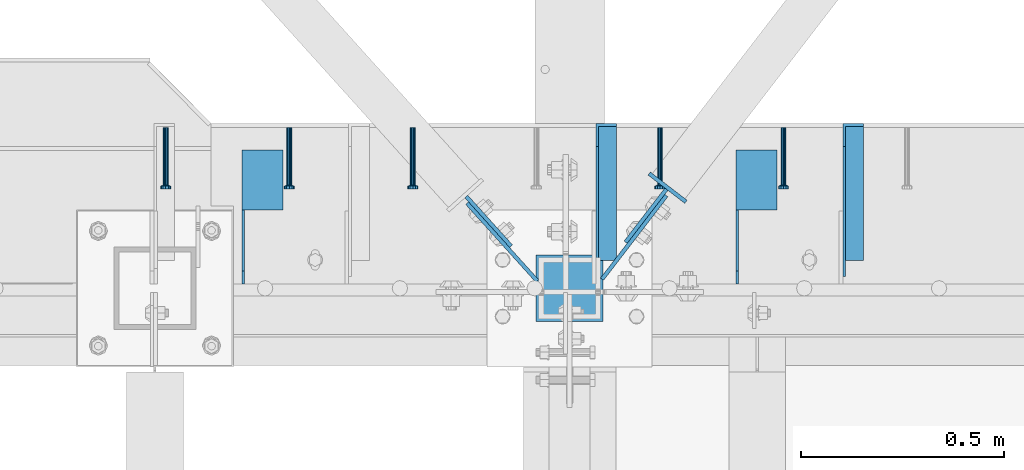
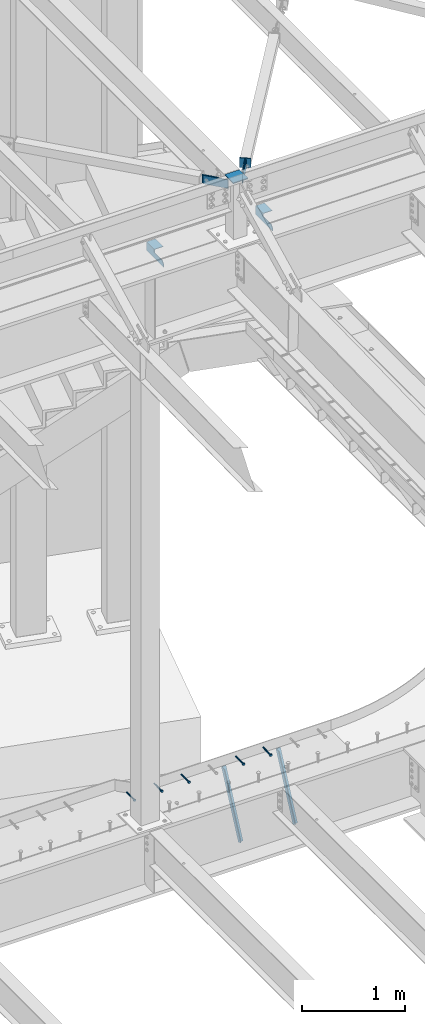
# One storey, part 1375 of 1763: 13 beams, 2 members, 10 elements without a shape of their own.
"""IFC2X3 building model written with IfcOpenShell, lengths in millimetres."""

from ifc_helpers import new_model, si_unit, frame, origin_with_axes, place, context, subcontext, project, spatial, faceted_brep, material, type_object, element, aggregate, save


model = new_model("IFC2X3")

# Units and contexts
model_context = context("Model", 3, precision=1e-05, world=origin_with_axes())
body_context = subcontext(model_context, "Body", "Model", "MODEL_VIEW")
ifc_project = project(units=[si_unit("LENGTHUNIT", "METRE", prefix="MILLI"), si_unit("AREAUNIT", "SQUARE_METRE"), si_unit("VOLUMEUNIT", "CUBIC_METRE"), si_unit("MASSUNIT", "GRAM", prefix="KILO"), si_unit("TIMEUNIT", "SECOND"), si_unit("PLANEANGLEUNIT", "RADIAN"), si_unit("SOLIDANGLEUNIT", "STERADIAN"), si_unit("THERMODYNAMICTEMPERATUREUNIT", "DEGREE_CELSIUS"), si_unit("LUMINOUSINTENSITYUNIT", "LUMEN")], contexts=[model_context])

# Site, building, storey
site_placement = place(None, origin_with_axes())
site = spatial("IfcSite", under=ifc_project, at=site_placement, CompositionType="ELEMENT")
building_placement = place(site_placement, origin_with_axes())
building = spatial("IfcBuilding", under=site, at=building_placement, Name="Undefined", CompositionType="ELEMENT")
storey_placement = place(building_placement, origin_with_axes())
storey = spatial("IfcBuildingStorey", under=building, at=storey_placement, Name="Undefined", CompositionType="ELEMENT", Elevation=0.0)

# Assembly, beam
assembly_1_placement = place(storey_placement, origin_with_axes())
assembly_1 = element("IfcElementAssembly", 1, at=assembly_1_placement, inside=storey, Name="HEADED STUD ANCHOR", AssemblyPlace="NOTDEFINED", PredefinedType="RIGID_FRAME")
ifc_material_1 = material(Name="STEEL/A108")
beam_type_1 = type_object("IfcBeamType", PredefinedType="NOTDEFINED")
beam_1_placement = place(assembly_1_placement, frame((-25449.0466486983, 52517.7065918569, 5264.23140606069), z_axis=(0.0, 0.0, 1.0), x_axis=(0.0, -1.0, 0.0)))
beam_1 = element("IfcBeam", 2, at=beam_1_placement, type_object=beam_type_1, material=ifc_material_1, Name="HEADED STUD ANCHOR", context=body_context, shape_type="Brep", body=[
    faceted_brep([(0.0, -3.1800000667572, 5.5), (0.0, -5.5, 3.1800000667572), (141.732000000002, -5.5, 3.1800000667572), (141.732000000002, -3.1800000667572, 5.5), (0.0, -6.34999999999491, 1.45519152283669e-11), (141.732000000002, -6.34999990463257, 0.0), (0.0, -5.5, -3.1800000667572), (141.732000000002, -5.5, -3.1800000667572), (0.0, -3.1800000667572, -5.5), (141.732000000002, -3.1800000667572, -5.5), (0.0, 0.0, -6.34999990463257), (141.732000000002, 0.0, -6.34999990463257), (0.0, 3.1800000667572, -5.5), (141.732000000002, 3.1800000667572, -5.5), (0.0, 5.5, -3.1800000667572), (141.732000000002, 5.5, -3.1800000667572), (0.0, 6.34999999999491, -2.91038304567337e-11), (141.732000000002, 6.34999990463257, 0.0), (0.0, 5.5, 3.1800000667572), (141.732000000002, 5.5, 3.1800000667572), (0.0, 3.1800000667572, 5.5), (141.732000000002, 3.1800000667572, 5.5), (0.0, 0.0, 6.34999990463257), (141.732000000002, 0.0, 6.34999990463257), (144.780000000001, -10.9899997711182, 6.34999990463257), (144.780000000001, -6.34000015258789, 10.9899997711182), (144.780000000001, -12.6999998092651, 0.0), (144.780000000001, -10.9899997711182, -6.34999990463257), (144.780000000001, -6.34000015258789, -10.9899997711182), (144.780000000001, 0.0, -12.6899995803833), (144.780000000001, 6.34000015258789, -10.9899997711182), (144.780000000001, 10.9899997711182, -6.34999990463257), (144.780000000001, 12.6999998092651, 0.0), (144.780000000001, 10.9899997711182, 6.34999990463257), (144.780000000001, 6.34000015258789, 10.9899997711182), (144.780000000001, 0.0, 12.6899995803833), (152.400000000001, -10.9899997711182, 6.34999990463257), (152.400000000001, -6.34000015258789, 10.9899997711182), (152.400000000001, -12.6999998092651, 0.0), (152.400000000001, -10.9899997711182, -6.34999990463257), (152.400000000001, -6.34000015258789, -10.9899997711182), (152.400000000001, 0.0, -12.6899995803833), (152.400000000001, 6.34000015258789, -10.9899997711182), (152.400000000001, 10.9899997711182, -6.34999990463257), (152.400000000001, 12.6999998092651, 0.0), (152.400000000001, 10.9899997711182, 6.34999990463257), (152.400000000001, 6.34000015258789, 10.9899997711182), (152.400000000001, 0.0, 12.6899995803833)], [[[0, 1, 2, 3]], [[1, 4, 5, 2]], [[4, 6, 7, 5]], [[6, 8, 9, 7]], [[8, 10, 11, 9]], [[10, 12, 13, 11]], [[12, 14, 15, 13]], [[14, 16, 17, 15]], [[16, 18, 19, 17]], [[18, 20, 21, 19]], [[20, 22, 23, 21]], [[22, 0, 3, 23]], [[22, 20, 18, 16, 14, 12, 10, 8, 6, 4, 1, 0]], [[3, 2, 24, 25]], [[2, 5, 26, 24]], [[5, 7, 27, 26]], [[7, 9, 28, 27]], [[9, 11, 29, 28]], [[11, 13, 30, 29]], [[13, 15, 31, 30]], [[15, 17, 32, 31]], [[17, 19, 33, 32]], [[19, 21, 34, 33]], [[21, 23, 35, 34]], [[23, 3, 25, 35]], [[25, 24, 36, 37]], [[24, 26, 38, 36]], [[26, 27, 39, 38]], [[27, 28, 40, 39]], [[28, 29, 41, 40]], [[29, 30, 42, 41]], [[30, 31, 43, 42]], [[31, 32, 44, 43]], [[32, 33, 45, 44]], [[33, 34, 46, 45]], [[34, 35, 47, 46]], [[35, 25, 37, 47]], [[38, 39, 40, 41, 42, 43, 44, 45, 46, 47, 37, 36]]]),
])
aggregate(assembly_1, [beam_1])

assembly_2_placement = place(storey_placement, origin_with_axes())
assembly_2 = element("IfcElementAssembly", 3, at=assembly_2_placement, inside=storey, Name="HEADED STUD ANCHOR", AssemblyPlace="NOTDEFINED", PredefinedType="RIGID_FRAME")
beam_2_placement = place(assembly_2_placement, frame((-25753.8466486983, 52517.7065918569, 5264.23140606069), z_axis=(0.0, 0.0, 1.0), x_axis=(0.0, -1.0, 0.0)))
beam_2 = element("IfcBeam", 4, at=beam_2_placement, type_object=beam_type_1, material=ifc_material_1, Name="HEADED STUD ANCHOR", context=body_context, shape_type="Brep", body=[
    faceted_brep([(0.0, -3.1800000667572, 5.5), (0.0, -5.5, 3.1800000667572), (141.732000000002, -5.5, 3.1800000667572), (141.732000000002, -3.1800000667572, 5.5), (0.0, -6.34999999999491, 1.45519152283669e-11), (141.732000000002, -6.34999990463257, 0.0), (0.0, -5.5, -3.1800000667572), (141.732000000002, -5.5, -3.1800000667572), (0.0, -3.1800000667572, -5.5), (141.732000000002, -3.1800000667572, -5.5), (0.0, 0.0, -6.34999990463257), (141.732000000002, 0.0, -6.34999990463257), (0.0, 3.1800000667572, -5.5), (141.732000000002, 3.1800000667572, -5.5), (0.0, 5.5, -3.1800000667572), (141.732000000002, 5.5, -3.1800000667572), (0.0, 6.34999999999491, -2.91038304567337e-11), (141.732000000002, 6.34999990463257, 0.0), (0.0, 5.5, 3.1800000667572), (141.732000000002, 5.5, 3.1800000667572), (0.0, 3.1800000667572, 5.5), (141.732000000002, 3.1800000667572, 5.5), (0.0, 0.0, 6.34999990463257), (141.732000000002, 0.0, 6.34999990463257), (144.780000000001, -10.9899997711182, 6.34999990463257), (144.780000000001, -6.34000015258789, 10.9899997711182), (144.780000000001, -12.6999998092651, 0.0), (144.780000000001, -10.9899997711182, -6.34999990463257), (144.780000000001, -6.34000015258789, -10.9899997711182), (144.780000000001, 0.0, -12.6899995803833), (144.780000000001, 6.34000015258789, -10.9899997711182), (144.780000000001, 10.9899997711182, -6.34999990463257), (144.780000000001, 12.6999998092651, 0.0), (144.780000000001, 10.9899997711182, 6.34999990463257), (144.780000000001, 6.34000015258789, 10.9899997711182), (144.780000000001, 0.0, 12.6899995803833), (152.400000000001, -10.9899997711182, 6.34999990463257), (152.400000000001, -6.34000015258789, 10.9899997711182), (152.400000000001, -12.6999998092651, 0.0), (152.400000000001, -10.9899997711182, -6.34999990463257), (152.400000000001, -6.34000015258789, -10.9899997711182), (152.400000000001, 0.0, -12.6899995803833), (152.400000000001, 6.34000015258789, -10.9899997711182), (152.400000000001, 10.9899997711182, -6.34999990463257), (152.400000000001, 12.6999998092651, 0.0), (152.400000000001, 10.9899997711182, 6.34999990463257), (152.400000000001, 6.34000015258789, 10.9899997711182), (152.400000000001, 0.0, 12.6899995803833)], [[[0, 1, 2, 3]], [[1, 4, 5, 2]], [[4, 6, 7, 5]], [[6, 8, 9, 7]], [[8, 10, 11, 9]], [[10, 12, 13, 11]], [[12, 14, 15, 13]], [[14, 16, 17, 15]], [[16, 18, 19, 17]], [[18, 20, 21, 19]], [[20, 22, 23, 21]], [[22, 0, 3, 23]], [[22, 20, 18, 16, 14, 12, 10, 8, 6, 4, 1, 0]], [[3, 2, 24, 25]], [[2, 5, 26, 24]], [[5, 7, 27, 26]], [[7, 9, 28, 27]], [[9, 11, 29, 28]], [[11, 13, 30, 29]], [[13, 15, 31, 30]], [[15, 17, 32, 31]], [[17, 19, 33, 32]], [[19, 21, 34, 33]], [[21, 23, 35, 34]], [[23, 3, 25, 35]], [[25, 24, 36, 37]], [[24, 26, 38, 36]], [[26, 27, 39, 38]], [[27, 28, 40, 39]], [[28, 29, 41, 40]], [[29, 30, 42, 41]], [[30, 31, 43, 42]], [[31, 32, 44, 43]], [[32, 33, 45, 44]], [[33, 34, 46, 45]], [[34, 35, 47, 46]], [[35, 25, 37, 47]], [[38, 39, 40, 41, 42, 43, 44, 45, 46, 47, 37, 36]]]),
])
aggregate(assembly_2, [beam_2])

assembly_3_placement = place(storey_placement, origin_with_axes())
assembly_3 = element("IfcElementAssembly", 5, at=assembly_3_placement, inside=storey, Name="HEADED STUD ANCHOR", AssemblyPlace="NOTDEFINED", PredefinedType="RIGID_FRAME")
beam_3_placement = place(assembly_3_placement, frame((-26363.4466486983, 52517.7065918569, 5264.23140606069), z_axis=(0.0, 0.0, 1.0), x_axis=(0.0, -1.0, 0.0)))
beam_3 = element("IfcBeam", 6, at=beam_3_placement, type_object=beam_type_1, material=ifc_material_1, Name="HEADED STUD ANCHOR", context=body_context, shape_type="Brep", body=[
    faceted_brep([(0.0, -3.1800000667572, 5.5), (0.0, -5.5, 3.1800000667572), (141.732000000002, -5.5, 3.1800000667572), (141.732000000002, -3.1800000667572, 5.5), (0.0, -6.34999999999491, 1.45519152283669e-11), (141.732000000002, -6.34999990463257, 0.0), (0.0, -5.5, -3.1800000667572), (141.732000000002, -5.5, -3.1800000667572), (0.0, -3.1800000667572, -5.5), (141.732000000002, -3.1800000667572, -5.5), (0.0, 0.0, -6.34999990463257), (141.732000000002, 0.0, -6.34999990463257), (0.0, 3.1800000667572, -5.5), (141.732000000002, 3.1800000667572, -5.5), (0.0, 5.5, -3.1800000667572), (141.732000000002, 5.5, -3.1800000667572), (0.0, 6.34999999999491, -2.91038304567337e-11), (141.732000000002, 6.34999990463257, 0.0), (0.0, 5.5, 3.1800000667572), (141.732000000002, 5.5, 3.1800000667572), (0.0, 3.1800000667572, 5.5), (141.732000000002, 3.1800000667572, 5.5), (0.0, 0.0, 6.34999990463257), (141.732000000002, 0.0, 6.34999990463257), (144.780000000001, -10.9899997711182, 6.34999990463257), (144.780000000001, -6.34000015258789, 10.9899997711182), (144.780000000001, -12.6999998092651, 0.0), (144.780000000001, -10.9899997711182, -6.34999990463257), (144.780000000001, -6.34000015258789, -10.9899997711182), (144.780000000001, 0.0, -12.6899995803833), (144.780000000001, 6.34000015258789, -10.9899997711182), (144.780000000001, 10.9899997711182, -6.34999990463257), (144.780000000001, 12.6999998092651, 0.0), (144.780000000001, 10.9899997711182, 6.34999990463257), (144.780000000001, 6.34000015258789, 10.9899997711182), (144.780000000001, 0.0, 12.6899995803833), (152.400000000001, -10.9899997711182, 6.34999990463257), (152.400000000001, -6.34000015258789, 10.9899997711182), (152.400000000001, -12.6999998092651, 0.0), (152.400000000001, -10.9899997711182, -6.34999990463257), (152.400000000001, -6.34000015258789, -10.9899997711182), (152.400000000001, 0.0, -12.6899995803833), (152.400000000001, 6.34000015258789, -10.9899997711182), (152.400000000001, 10.9899997711182, -6.34999990463257), (152.400000000001, 12.6999998092651, 0.0), (152.400000000001, 10.9899997711182, 6.34999990463257), (152.400000000001, 6.34000015258789, 10.9899997711182), (152.400000000001, 0.0, 12.6899995803833)], [[[0, 1, 2, 3]], [[1, 4, 5, 2]], [[4, 6, 7, 5]], [[6, 8, 9, 7]], [[8, 10, 11, 9]], [[10, 12, 13, 11]], [[12, 14, 15, 13]], [[14, 16, 17, 15]], [[16, 18, 19, 17]], [[18, 20, 21, 19]], [[20, 22, 23, 21]], [[22, 0, 3, 23]], [[22, 20, 18, 16, 14, 12, 10, 8, 6, 4, 1, 0]], [[3, 2, 24, 25]], [[2, 5, 26, 24]], [[5, 7, 27, 26]], [[7, 9, 28, 27]], [[9, 11, 29, 28]], [[11, 13, 30, 29]], [[13, 15, 31, 30]], [[15, 17, 32, 31]], [[17, 19, 33, 32]], [[19, 21, 34, 33]], [[21, 23, 35, 34]], [[23, 3, 25, 35]], [[25, 24, 36, 37]], [[24, 26, 38, 36]], [[26, 27, 39, 38]], [[27, 28, 40, 39]], [[28, 29, 41, 40]], [[29, 30, 42, 41]], [[30, 31, 43, 42]], [[31, 32, 44, 43]], [[32, 33, 45, 44]], [[33, 34, 46, 45]], [[34, 35, 47, 46]], [[35, 25, 37, 47]], [[38, 39, 40, 41, 42, 43, 44, 45, 46, 47, 37, 36]]]),
])
aggregate(assembly_3, [beam_3])

assembly_4_placement = place(storey_placement, origin_with_axes())
assembly_4 = element("IfcElementAssembly", 7, at=assembly_4_placement, inside=storey, Name="HEADED STUD ANCHOR", AssemblyPlace="NOTDEFINED", PredefinedType="RIGID_FRAME")
beam_4_placement = place(assembly_4_placement, frame((-26668.2466486983, 52517.7065918569, 5264.23140606069), z_axis=(0.0, 0.0, 1.0), x_axis=(0.0, -1.0, 0.0)))
beam_4 = element("IfcBeam", 8, at=beam_4_placement, type_object=beam_type_1, material=ifc_material_1, Name="HEADED STUD ANCHOR", context=body_context, shape_type="Brep", body=[
    faceted_brep([(0.0, -3.1800000667572, 5.5), (0.0, -5.5, 3.1800000667572), (141.732000000002, -5.5, 3.1800000667572), (141.732000000002, -3.1800000667572, 5.5), (0.0, -6.34999999999491, 1.45519152283669e-11), (141.732000000002, -6.34999990463257, 0.0), (0.0, -5.5, -3.1800000667572), (141.732000000002, -5.5, -3.1800000667572), (0.0, -3.1800000667572, -5.5), (141.732000000002, -3.1800000667572, -5.5), (0.0, 0.0, -6.34999990463257), (141.732000000002, 0.0, -6.34999990463257), (0.0, 3.1800000667572, -5.5), (141.732000000002, 3.1800000667572, -5.5), (0.0, 5.5, -3.1800000667572), (141.732000000002, 5.5, -3.1800000667572), (0.0, 6.34999999999491, -2.91038304567337e-11), (141.732000000002, 6.34999990463257, 0.0), (0.0, 5.5, 3.1800000667572), (141.732000000002, 5.5, 3.1800000667572), (0.0, 3.1800000667572, 5.5), (141.732000000002, 3.1800000667572, 5.5), (0.0, 0.0, 6.34999990463257), (141.732000000002, 0.0, 6.34999990463257), (144.780000000001, -10.9899997711182, 6.34999990463257), (144.780000000001, -6.34000015258789, 10.9899997711182), (144.780000000001, -12.6999998092651, 0.0), (144.780000000001, -10.9899997711182, -6.34999990463257), (144.780000000001, -6.34000015258789, -10.9899997711182), (144.780000000001, 0.0, -12.6899995803833), (144.780000000001, 6.34000015258789, -10.9899997711182), (144.780000000001, 10.9899997711182, -6.34999990463257), (144.780000000001, 12.6999998092651, 0.0), (144.780000000001, 10.9899997711182, 6.34999990463257), (144.780000000001, 6.34000015258789, 10.9899997711182), (144.780000000001, 0.0, 12.6899995803833), (152.400000000001, -10.9899997711182, 6.34999990463257), (152.400000000001, -6.34000015258789, 10.9899997711182), (152.400000000001, -12.6999998092651, 0.0), (152.400000000001, -10.9899997711182, -6.34999990463257), (152.400000000001, -6.34000015258789, -10.9899997711182), (152.400000000001, 0.0, -12.6899995803833), (152.400000000001, 6.34000015258789, -10.9899997711182), (152.400000000001, 10.9899997711182, -6.34999990463257), (152.400000000001, 12.6999998092651, 0.0), (152.400000000001, 10.9899997711182, 6.34999990463257), (152.400000000001, 6.34000015258789, 10.9899997711182), (152.400000000001, 0.0, 12.6899995803833)], [[[0, 1, 2, 3]], [[1, 4, 5, 2]], [[4, 6, 7, 5]], [[6, 8, 9, 7]], [[8, 10, 11, 9]], [[10, 12, 13, 11]], [[12, 14, 15, 13]], [[14, 16, 17, 15]], [[16, 18, 19, 17]], [[18, 20, 21, 19]], [[20, 22, 23, 21]], [[22, 0, 3, 23]], [[22, 20, 18, 16, 14, 12, 10, 8, 6, 4, 1, 0]], [[3, 2, 24, 25]], [[2, 5, 26, 24]], [[5, 7, 27, 26]], [[7, 9, 28, 27]], [[9, 11, 29, 28]], [[11, 13, 30, 29]], [[13, 15, 31, 30]], [[15, 17, 32, 31]], [[17, 19, 33, 32]], [[19, 21, 34, 33]], [[21, 23, 35, 34]], [[23, 3, 25, 35]], [[25, 24, 36, 37]], [[24, 26, 38, 36]], [[26, 27, 39, 38]], [[27, 28, 40, 39]], [[28, 29, 41, 40]], [[29, 30, 42, 41]], [[30, 31, 43, 42]], [[31, 32, 44, 43]], [[32, 33, 45, 44]], [[33, 34, 46, 45]], [[34, 35, 47, 46]], [[35, 25, 37, 47]], [[38, 39, 40, 41, 42, 43, 44, 45, 46, 47, 37, 36]]]),
])
aggregate(assembly_4, [beam_4])

assembly_5_placement = place(storey_placement, origin_with_axes())
assembly_5 = element("IfcElementAssembly", 9, at=assembly_5_placement, inside=storey, Name="HEADED STUD ANCHOR", AssemblyPlace="NOTDEFINED", PredefinedType="RIGID_FRAME")
beam_5_placement = place(assembly_5_placement, frame((-26973.0466486983, 52517.7065918569, 5264.23140606069), z_axis=(0.0, 0.0, 1.0), x_axis=(0.0, -1.0, 0.0)))
beam_5 = element("IfcBeam", 10, at=beam_5_placement, type_object=beam_type_1, material=ifc_material_1, Name="HEADED STUD ANCHOR", context=body_context, shape_type="Brep", body=[
    faceted_brep([(0.0, -3.1800000667572, 5.5), (0.0, -5.5, 3.1800000667572), (141.732000000002, -5.5, 3.1800000667572), (141.732000000002, -3.1800000667572, 5.5), (0.0, -6.34999999999491, 1.45519152283669e-11), (141.732000000002, -6.34999990463257, 0.0), (0.0, -5.5, -3.1800000667572), (141.732000000002, -5.5, -3.1800000667572), (0.0, -3.1800000667572, -5.5), (141.732000000002, -3.1800000667572, -5.5), (0.0, 0.0, -6.34999990463257), (141.732000000002, 0.0, -6.34999990463257), (0.0, 3.1800000667572, -5.5), (141.732000000002, 3.1800000667572, -5.5), (0.0, 5.5, -3.1800000667572), (141.732000000002, 5.5, -3.1800000667572), (0.0, 6.34999999999491, -2.91038304567337e-11), (141.732000000002, 6.34999990463257, 0.0), (0.0, 5.5, 3.1800000667572), (141.732000000002, 5.5, 3.1800000667572), (0.0, 3.1800000667572, 5.5), (141.732000000002, 3.1800000667572, 5.5), (0.0, 0.0, 6.34999990463257), (141.732000000002, 0.0, 6.34999990463257), (144.780000000001, -10.9899997711182, 6.34999990463257), (144.780000000001, -6.34000015258789, 10.9899997711182), (144.780000000001, -12.6999998092651, 0.0), (144.780000000001, -10.9899997711182, -6.34999990463257), (144.780000000001, -6.34000015258789, -10.9899997711182), (144.780000000001, 0.0, -12.6899995803833), (144.780000000001, 6.34000015258789, -10.9899997711182), (144.780000000001, 10.9899997711182, -6.34999990463257), (144.780000000001, 12.6999998092651, 0.0), (144.780000000001, 10.9899997711182, 6.34999990463257), (144.780000000001, 6.34000015258789, 10.9899997711182), (144.780000000001, 0.0, 12.6899995803833), (152.400000000001, -10.9899997711182, 6.34999990463257), (152.400000000001, -6.34000015258789, 10.9899997711182), (152.400000000001, -12.6999998092651, 0.0), (152.400000000001, -10.9899997711182, -6.34999990463257), (152.400000000001, -6.34000015258789, -10.9899997711182), (152.400000000001, 0.0, -12.6899995803833), (152.400000000001, 6.34000015258789, -10.9899997711182), (152.400000000001, 10.9899997711182, -6.34999990463257), (152.400000000001, 12.6999998092651, 0.0), (152.400000000001, 10.9899997711182, 6.34999990463257), (152.400000000001, 6.34000015258789, 10.9899997711182), (152.400000000001, 0.0, 12.6899995803833)], [[[0, 1, 2, 3]], [[1, 4, 5, 2]], [[4, 6, 7, 5]], [[6, 8, 9, 7]], [[8, 10, 11, 9]], [[10, 12, 13, 11]], [[12, 14, 15, 13]], [[14, 16, 17, 15]], [[16, 18, 19, 17]], [[18, 20, 21, 19]], [[20, 22, 23, 21]], [[22, 0, 3, 23]], [[22, 20, 18, 16, 14, 12, 10, 8, 6, 4, 1, 0]], [[3, 2, 24, 25]], [[2, 5, 26, 24]], [[5, 7, 27, 26]], [[7, 9, 28, 27]], [[9, 11, 29, 28]], [[11, 13, 30, 29]], [[13, 15, 31, 30]], [[15, 17, 32, 31]], [[17, 19, 33, 32]], [[19, 21, 34, 33]], [[21, 23, 35, 34]], [[23, 3, 25, 35]], [[25, 24, 36, 37]], [[24, 26, 38, 36]], [[26, 27, 39, 38]], [[27, 28, 40, 39]], [[28, 29, 41, 40]], [[29, 30, 42, 41]], [[30, 31, 43, 42]], [[31, 32, 44, 43]], [[32, 33, 45, 44]], [[33, 34, 46, 45]], [[34, 35, 47, 46]], [[35, 25, 37, 47]], [[38, 39, 40, 41, 42, 43, 44, 45, 46, 47, 37, 36]]]),
])
aggregate(assembly_5, [beam_5])

# Assembly, members
assembly_6_placement = place(storey_placement, origin_with_axes())
assembly_6 = element("IfcElementAssembly", 11, at=assembly_6_placement, inside=storey, Name="BEAM", AssemblyPlace="NOTDEFINED", PredefinedType="RIGID_FRAME")
ifc_material_2 = material(Name="STEEL/A36")
member_type = type_object("IfcMemberType", Name="L2X2X1/4", PredefinedType="NOTDEFINED")
member_1_placement = place(assembly_6_placement, frame((-25277.0370109278, 52172.6912662575, 4509.47070362112), z_axis=(0.0, -0.902782435029662, 0.430097518014128), x_axis=(0.0, 0.43009751801413, 0.902782435029662)))
member_1 = element("IfcMember", 12, at=member_1_placement, type_object=member_type, material=ifc_material_2, Name="ANGLE", ObjectType="L2X2X1/4", context=body_context, shape_type="Brep", body=[
    faceted_brep([(-1.45519152283669e-11, 25.4000000000015, -25.3999999999869), (1.45519152283669e-11, 25.4000000000015, 25.3999999999796), (746.475333672606, 25.4000000000015, 25.3999999987791), (770.677127003386, 25.4000000000015, -25.400000001122), (1.45519152283669e-11, 19.0499999999993, 25.3999999999796), (746.475333672606, 19.0499999999993, 25.3999999987791), (-7.27595761418343e-12, 19.0499999999993, -19.0499999999956), (767.651902837039, 19.0499999999993, -19.050000001138), (-7.27595761418343e-12, -25.4000000000015, -19.0499999999956), (767.651902837039, -25.4000000000015, -19.050000001138), (-1.45519152283669e-11, -25.4000000000015, -25.3999999999869), (770.677127003386, -25.4000000000015, -25.400000001122)], [[[0, 1, 2, 3]], [[1, 4, 5, 2]], [[4, 6, 7, 5]], [[6, 8, 9, 7]], [[8, 10, 11, 9]], [[10, 0, 3, 11]], [[5, 7, 9, 11, 3, 2]], [[10, 8, 6, 4, 1, 0]]]),
])
member_2_placement = place(assembly_6_placement, frame((-25886.6370109278, 52172.6912662575, 4509.47070362112), z_axis=(0.0, -0.902782435029662, 0.430097518014128), x_axis=(0.0, 0.43009751801413, 0.902782435029662)))
member_2 = element("IfcMember", 13, at=member_2_placement, type_object=member_type, material=ifc_material_2, Name="ANGLE", ObjectType="L2X2X1/4", context=body_context, shape_type="Brep", body=[
    faceted_brep([(-1.45519152283669e-11, 25.4000000000015, -25.3999999999869), (1.45519152283669e-11, 25.4000000000015, 25.3999999999796), (746.475333672606, 25.4000000000015, 25.3999999987791), (770.677127003386, 25.4000000000015, -25.400000001122), (1.45519152283669e-11, 19.0499999999993, 25.3999999999796), (746.475333672606, 19.0499999999993, 25.3999999987791), (-7.27595761418343e-12, 19.0499999999993, -19.0499999999956), (767.651902837039, 19.0499999999993, -19.050000001138), (-7.27595761418343e-12, -25.4000000000015, -19.0499999999956), (767.651902837039, -25.4000000000015, -19.050000001138), (-1.45519152283669e-11, -25.4000000000015, -25.3999999999869), (770.677127003386, -25.4000000000015, -25.400000001122)], [[[0, 1, 2, 3]], [[1, 4, 5, 2]], [[4, 6, 7, 5]], [[6, 8, 9, 7]], [[8, 10, 11, 9]], [[10, 0, 3, 11]], [[5, 7, 9, 11, 3, 2]], [[10, 8, 6, 4, 1, 0]]]),
])
aggregate(assembly_6, [member_1, member_2])

# Assembly, beams
assembly_7_placement = place(storey_placement, origin_with_axes())
assembly_7 = element("IfcElementAssembly", 14, at=assembly_7_placement, inside=storey, Name="BEAM", AssemblyPlace="NOTDEFINED", PredefinedType="RIGID_FRAME")
beam_type_2 = type_object("IfcBeamType", Name="L4X4X1/4", PredefinedType="NOTDEFINED")
beam_6_placement = place(assembly_7_placement, frame((-25515.3247736984, 52462.1124819023, 11696.6999917654), z_axis=(0.0, 0.0, -1.0), x_axis=(0.0, -1.0, 0.0)))
beam_6 = element("IfcBeam", 15, at=beam_6_placement, type_object=beam_type_2, material=ifc_material_2, Name="BRACE", ObjectType="L4X4X1/4", context=body_context, shape_type="Brep", body=[
    faceted_brep([(148.43173432786, 44.4500000000007, -44.4500000000007), (148.431790430077, -50.7999999999993, -44.4500000000007), (148.431790785675, -50.7999999999993, -50.7999999999993), (148.43173094331, 50.7999999999993, -50.7999999999993), (148.431728809323, 50.7999999999993, -12.6999970794623), (148.431732549492, 44.4500000000007, -12.6999970794623), (299.243731689443, 50.7999999999993, -12.7000043904281), (299.243731689443, 44.4499999999971, -12.7000043904281), (2.11002770811319e-10, -50.8000000000357, -50.799999999952), (1.96450855582952e-10, -50.8000000000338, -44.4499999999534), (-2.18278728425503e-11, 44.4500000000007, -44.450000000048), (-1.81898940354586e-10, 44.4500000000371, 50.7999999999374), (-1.96450855582952e-10, 50.8000000000393, 50.7999999999374), (-3.63797880709171e-11, 50.8000000000011, -50.8000000000538), (330.993731689443, 44.4500000000007, 50.7999999999993), (330.993731689443, 50.7999999999993, 50.7999999999993), (330.993731689443, 44.4500000000007, 19.050000000012), (330.993731689443, 50.7999999999993, 19.050000000012)], [[[0, 1, 2, 3, 4, 5]], [[5, 4, 6, 7]], [[8, 9, 10, 11, 12, 13]], [[12, 11, 14, 15]], [[15, 14, 16, 17]], [[16, 7, 6, 17]], [[4, 3, 13, 12, 15, 17, 6]], [[8, 13, 3, 2]], [[9, 8, 2, 1]], [[10, 9, 1, 0]], [[14, 11, 10, 0, 5, 7, 16]]]),
])
beam_7_placement = place(assembly_7_placement, frame((-26734.5247736984, 52462.1124819023, 11696.6999917654), z_axis=(0.0, 0.0, -1.0), x_axis=(0.0, -1.0, 0.0)))
beam_7 = element("IfcBeam", 16, at=beam_7_placement, type_object=beam_type_2, material=ifc_material_2, Name="BRACE", ObjectType="L4X4X1/4", context=body_context, shape_type="Brep", body=[
    faceted_brep([(148.43173432786, 44.4500000000007, -44.4500000000007), (148.431790430077, -50.7999999999993, -44.4500000000007), (148.431790785675, -50.7999999999993, -50.7999999999993), (148.43173094331, 50.7999999999993, -50.7999999999993), (148.431728809323, 50.7999999999993, -12.6999970794623), (148.431732549492, 44.4500000000007, -12.6999970794623), (299.243731689443, 50.7999999999993, -12.7000043904281), (299.243731689443, 44.4499999999971, -12.7000043904281), (2.11002770811319e-10, -50.8000000000357, -50.799999999952), (1.96450855582952e-10, -50.8000000000338, -44.4499999999534), (-2.18278728425503e-11, 44.4500000000007, -44.450000000048), (-1.81898940354586e-10, 44.4500000000371, 50.7999999999374), (-1.96450855582952e-10, 50.8000000000393, 50.7999999999374), (-3.63797880709171e-11, 50.8000000000011, -50.8000000000538), (330.993731689443, 44.4500000000007, 50.7999999999993), (330.993731689443, 50.7999999999993, 50.7999999999993), (330.993731689443, 44.4500000000007, 19.050000000012), (330.993731689443, 50.7999999999993, 19.050000000012)], [[[0, 1, 2, 3, 4, 5]], [[5, 4, 6, 7]], [[8, 9, 10, 11, 12, 13]], [[12, 11, 14, 15]], [[15, 14, 16, 17]], [[16, 7, 6, 17]], [[4, 3, 13, 12, 15, 17, 6]], [[8, 13, 3, 2]], [[9, 8, 2, 1]], [[10, 9, 1, 0]], [[14, 11, 10, 0, 5, 7, 16]]]),
])
aggregate(assembly_7, [beam_6, beam_7])

# Assembly, beam
assembly_8_placement = place(storey_placement, origin_with_axes())
assembly_8 = element("IfcElementAssembly", 17, at=assembly_8_placement, inside=storey, Name="COLUMN", AssemblyPlace="NOTDEFINED", PredefinedType="RIGID_FRAME")
beam_type_3 = type_object("IfcBeamType", PredefinedType="NOTDEFINED")
beam_8_placement = place(assembly_8_placement, frame((-25817.2511839838, 52246.2646151068, 12422.1875), z_axis=(-0.609825086268847, -0.792536033349395, 0.0), x_axis=(0.0, 0.0, -1.0)))
beam_8 = element("IfcBeam", 18, at=beam_8_placement, type_object=beam_type_3, material=ifc_material_2, Name="PLATE", context=body_context, shape_type="Brep", body=[
    faceted_brep([(0.0, 4.76250000039727, -130.17499999985), (0.0, 4.76250000000073, 130.175003051758), (101.599999999999, 4.76249999958964, 130.174999999839), (101.599999999999, 4.76250000039727, -130.17499999985), (0.0, -4.76250000000073, 130.175003051758), (101.599999999999, -4.7625000004191, 130.174999999828), (0.0, -4.76249999961874, -130.174999999857), (101.599999999999, -4.76249999961874, -130.174999999857)], [[[0, 1, 2, 3]], [[1, 4, 5, 2]], [[4, 6, 7, 5]], [[6, 0, 3, 7]], [[5, 7, 3, 2]], [[6, 4, 1, 0]]]),
])

assembly_9_placement = place(storey_placement, origin_with_axes())
assembly_9 = element("IfcElementAssembly", 19, at=assembly_9_placement, inside=storey, Name="H. BRACE", AssemblyPlace="NOTDEFINED", PredefinedType="RIGID_FRAME")
beam_9_placement = place(assembly_9_placement, frame((-25788.1103278118, 52299.7556558846, 12422.1875), z_axis=(-0.609825086268847, -0.792536033349395, 0.0), x_axis=(0.0, 0.0, -1.0)))
beam_9 = element("IfcBeam", 20, at=beam_9_placement, type_object=beam_type_3, material=ifc_material_2, Name="PLATE", context=body_context, shape_type="Brep", body=[
    faceted_brep([(0.0, 4.7625000001417, -82.5500000001048), (0.0, 4.76249999986885, 82.5500000001339), (101.599999999999, 4.76249999986885, 82.5500000001339), (101.599999999999, 4.7625000001417, -82.5500000001048), (0.0, -4.76250000014352, 82.5500000001193), (101.599999999999, -4.76250000014352, 82.5500000001193), (0.0, -4.76249999987067, -82.5500000001193), (101.599999999999, -4.76249999987067, -82.5500000001193)], [[[0, 1, 2, 3]], [[1, 4, 5, 2]], [[4, 6, 7, 5]], [[6, 0, 3, 7]], [[5, 7, 3, 2]], [[6, 4, 1, 0]]]),
])

# Beam
beam_10_placement = place(assembly_8_placement, frame((-26142.9709115413, 52234.7808697385, 12422.1875), z_axis=(0.669524421073345, -0.742790044081369, 0.0), x_axis=(0.0, 0.0, -1.0)))
beam_10 = element("IfcBeam", 21, at=beam_10_placement, type_object=beam_type_3, material=ifc_material_2, Name="PLATE", context=body_context, shape_type="Brep", body=[
    faceted_brep([(0.0, 4.76249999984611, -129.381000000176), (0.0, 4.76250000012988, 129.381000000161), (101.599999999999, 4.76250000012988, 129.381000000161), (101.599999999999, 4.76249999984611, -129.381000000176), (0.0, -4.76249999985703, 129.381000000147), (101.599999999999, -4.76249999985703, 129.381000000147), (0.0, -4.76250000014443, -129.38100000019), (101.599999999999, -4.76250000014443, -129.38100000019)], [[[0, 1, 2, 3]], [[1, 4, 5, 2]], [[4, 6, 7, 5]], [[6, 0, 3, 7]], [[5, 7, 3, 2]], [[6, 4, 1, 0]]]),
])

# Assembly, beam
assembly_10_placement = place(storey_placement, origin_with_axes())
assembly_10 = element("IfcElementAssembly", 22, at=assembly_10_placement, inside=storey, Name="H. BRACE", AssemblyPlace="NOTDEFINED", PredefinedType="RIGID_FRAME")
beam_11_placement = place(assembly_10_placement, frame((-26176.1025395837, 52285.7642927784, 12422.1875), z_axis=(0.669524421073345, -0.742790044081369, 0.0), x_axis=(0.0, 0.0, -1.0)))
beam_11 = element("IfcBeam", 23, at=beam_11_placement, type_object=beam_type_3, material=ifc_material_2, Name="PLATE", context=body_context, shape_type="Brep", body=[
    faceted_brep([(0.0, 4.7625000001417, -82.5500000001048), (0.0, 4.76249999986885, 82.5500000001339), (101.599999999999, 4.76249999986885, 82.5500000001339), (101.599999999999, 4.7625000001417, -82.5500000001048), (0.0, -4.76250000014352, 82.5500000001193), (101.599999999999, -4.76250000014352, 82.5500000001193), (0.0, -4.76249999987067, -82.5500000001193), (101.599999999999, -4.76249999987067, -82.5500000001193)], [[[0, 1, 2, 3]], [[1, 4, 5, 2]], [[4, 6, 7, 5]], [[6, 0, 3, 7]], [[5, 7, 3, 2]], [[6, 4, 1, 0]]]),
])
aggregate(assembly_10, [beam_11])

# Beam
beam_type_4 = type_object("IfcBeamType", PredefinedType="NOTDEFINED")
beam_12_placement = place(assembly_9_placement, frame((-25734.8649749668, 52368.953958296, 12428.5375), z_axis=(0.792536033349398, -0.609825086268843, 0.0), x_axis=(0.0, 0.0, -1.0)))
beam_12 = element("IfcBeam", 24, at=beam_12_placement, type_object=beam_type_4, material=ifc_material_2, Name="PLATE", context=body_context, shape_type="Brep", body=[
    faceted_brep([(0.0, 4.76249999989523, -57.1500000001702), (0.0, 4.76250000014261, 57.1500000001565), (114.299999999999, 4.76250000014261, 57.1500000001565), (114.299999999999, 4.76249999989523, -57.1500000001702), (0.0, -4.76249999988067, 57.1500000001784), (114.299999999999, -4.76249999988067, 57.1500000001784), (0.0, -4.76250000012806, -57.150000000152), (114.299999999999, -4.76250000012806, -57.150000000152)], [[[0, 1, 2, 3]], [[1, 4, 5, 2]], [[4, 6, 7, 5]], [[6, 0, 3, 7]], [[5, 7, 3, 2]], [[6, 4, 1, 0]]]),
])

aggregate(assembly_9, [beam_12, beam_9])

beam_type_5 = type_object("IfcBeamType", PredefinedType="NOTDEFINED")
beam_13_placement = place(assembly_8_placement, frame((-25976.6096174479, 52038.250000001, 12439.65), z_axis=(1.0, 0.0, 0.0), x_axis=(0.0, 1.0, 0.0)))
beam_13 = element("IfcBeam", 25, at=beam_13_placement, type_object=beam_type_5, material=ifc_material_2, Name="PLATE", context=body_context, shape_type="Brep", body=[
    faceted_brep([(0.0, 6.35000000000036, -82.5499999999993), (0.0, 6.35000000000036, 82.5499999999993), (165.099999999991, 6.35000000000036, 82.5499999999993), (165.099999999991, 6.35000000000036, -82.5499999999993), (0.0, -6.35000000000036, 82.5499999999993), (165.099999999991, -6.35000000000036, 82.5499999999993), (0.0, -6.35000000000036, -82.5499999999993), (165.099999999991, -6.35000000000036, -82.5499999999993)], [[[0, 1, 2, 3]], [[1, 4, 5, 2]], [[4, 6, 7, 5]], [[6, 0, 3, 7]], [[5, 7, 3, 2]], [[6, 4, 1, 0]]]),
])

aggregate(assembly_8, [beam_8, beam_10, beam_13])

save(model, "model.ifc")
